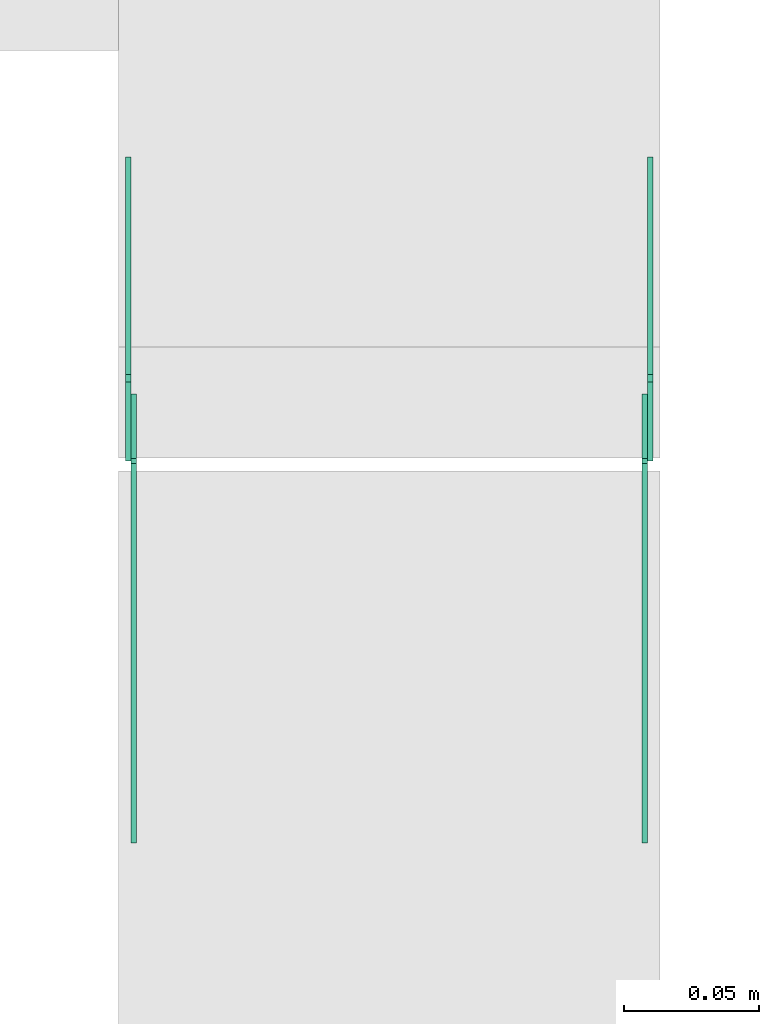
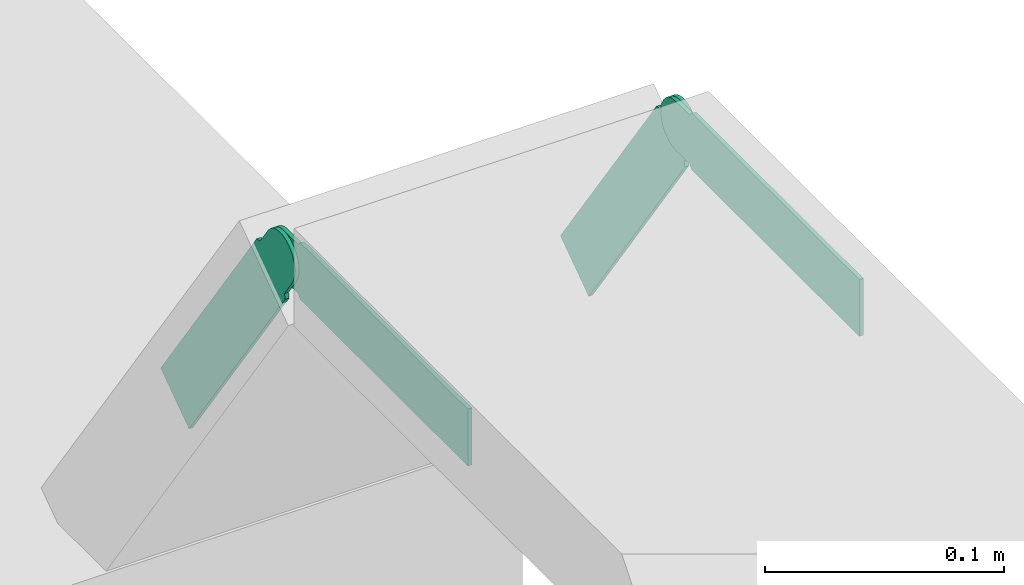
# One storey, part 26 of 27: 4 flow fittings.
"""IFC2X3 building model written with IfcOpenShell, lengths in millimetres."""

from ifc_helpers import new_model, entity, si_unit, converted_unit, derived_unit, direction, frame, frame_2d, origin, place, context, subcontext, project, spatial, polyline, circle_curve, parameter, trimmed, segment, composite_curve, outline, extrude, source, transform, mapped, material, type_object, type_shapes, element, save


model = new_model("IFC2X3")

# Units and contexts
model_context = context("Model", 3, precision=0.01, world=origin(), true_north=direction((6.12303176911189e-17, 1.0)))
body_context = subcontext(model_context, "Body", "Model", "MODEL_VIEW")
ifc_project = project(units=[si_unit("LENGTHUNIT", "METRE", prefix="MILLI"), si_unit("AREAUNIT", "SQUARE_METRE"), si_unit("VOLUMEUNIT", "CUBIC_METRE"), converted_unit("PLANEANGLEUNIT", "DEGREE", entity("IfcRatioMeasure", 0.0174532925199433), si_unit("PLANEANGLEUNIT", "RADIAN"), dimensions=[0, 0, 0, 0, 0, 0, 0]), si_unit("MASSUNIT", "GRAM", prefix="KILO"), derived_unit("MASSDENSITYUNIT", [(si_unit("MASSUNIT", "GRAM", prefix="KILO"), 1), (si_unit("LENGTHUNIT", "METRE"), -3)]), derived_unit("MOMENTOFINERTIAUNIT", [(si_unit("LENGTHUNIT", "METRE"), 4)]), si_unit("TIMEUNIT", "SECOND"), si_unit("FREQUENCYUNIT", "HERTZ"), si_unit("THERMODYNAMICTEMPERATUREUNIT", "DEGREE_CELSIUS"), derived_unit("THERMALTRANSMITTANCEUNIT", [(si_unit("MASSUNIT", "GRAM", prefix="KILO"), 1), (si_unit("THERMODYNAMICTEMPERATUREUNIT", "KELVIN"), -1), (si_unit("TIMEUNIT", "SECOND"), -3)]), derived_unit("VOLUMETRICFLOWRATEUNIT", [(si_unit("LENGTHUNIT", "METRE"), 3), (si_unit("TIMEUNIT", "SECOND"), -1)]), derived_unit("MASSFLOWRATEUNIT", [(si_unit("MASSUNIT", "GRAM", prefix="KILO"), 1), (si_unit("TIMEUNIT", "SECOND"), -1)]), derived_unit("ROTATIONALFREQUENCYUNIT", [(si_unit("TIMEUNIT", "SECOND"), -1)]), si_unit("ELECTRICCURRENTUNIT", "AMPERE"), si_unit("ELECTRICVOLTAGEUNIT", "VOLT"), si_unit("POWERUNIT", "WATT"), si_unit("FORCEUNIT", "NEWTON", prefix="KILO"), si_unit("ILLUMINANCEUNIT", "LUX"), si_unit("LUMINOUSFLUXUNIT", "LUMEN"), si_unit("LUMINOUSINTENSITYUNIT", "CANDELA"), derived_unit("USERDEFINED", [(si_unit("MASSUNIT", "GRAM", prefix="KILO"), -1), (si_unit("LENGTHUNIT", "METRE"), -2), (si_unit("TIMEUNIT", "SECOND"), 3), (si_unit("LUMINOUSFLUXUNIT", "LUMEN"), 1)]), derived_unit("LINEARVELOCITYUNIT", [(si_unit("LENGTHUNIT", "METRE"), 1), (si_unit("TIMEUNIT", "SECOND"), -1)]), si_unit("PRESSUREUNIT", "PASCAL"), derived_unit("USERDEFINED", [(si_unit("LENGTHUNIT", "METRE"), -2), (si_unit("MASSUNIT", "GRAM", prefix="KILO"), 1), (si_unit("TIMEUNIT", "SECOND"), -2)]), derived_unit("LINEARFORCEUNIT", [(si_unit("MASSUNIT", "GRAM", prefix="KILO"), 1), (si_unit("LENGTHUNIT", "METRE"), 1), (si_unit("TIMEUNIT", "SECOND"), -2), (si_unit("LENGTHUNIT", "METRE"), -1)]), derived_unit("PLANARFORCEUNIT", [(si_unit("MASSUNIT", "GRAM", prefix="KILO"), 1), (si_unit("LENGTHUNIT", "METRE"), 1), (si_unit("TIMEUNIT", "SECOND"), -2), (si_unit("LENGTHUNIT", "METRE"), -2)])], contexts=[model_context])

# Site, building, storey
site_placement = place(None, origin())
site = spatial("IfcSite", under=ifc_project, at=site_placement, CompositionType="ELEMENT")
building_placement = place(site_placement, origin())
building = spatial("IfcBuilding", under=site, at=building_placement, CompositionType="ELEMENT")
storey_placement = place(building_placement, origin())
storey = spatial("IfcBuildingStorey", under=building, at=storey_placement, CompositionType="ELEMENT", Elevation=0.0)

# Flow fittings
ifc_material = material(Name="G")
cable_carrier_fitting_type_1 = type_object("IfcCableCarrierFittingType", PredefinedType="NOTDEFINED", material=ifc_material)
shared_shape_1 = source(origin(), body_context, "Body", "SweptSolid", [
    extrude(outline(composite_curve([segment(trimmed(circle_curve(frame_2d((-44.59, 0.0), x_axis=(1.0, 0.0)), 12.5), [parameter(90.0000000000007)], [parameter(270.0)], True, "PARAMETER"), True, "CONTINUOUS"), segment(polyline([(-44.59, -12.5), (-33.09, -12.5)]), True, "CONTINUOUS"), segment(polyline([(-33.09, -12.5), (-31.23, -14.5)]), True, "CONTINUOUS"), segment(polyline([(-31.23, -14.5), (108.91, -14.5)]), True, "CONTINUOUS"), segment(polyline([(108.91, -14.5), (108.91, 14.5)]), True, "CONTINUOUS"), segment(polyline([(108.91, 14.5), (-31.23, 14.5)]), True, "CONTINUOUS"), segment(polyline([(-31.23, 14.5), (-33.09, 12.5)]), True, "CONTINUOUS"), segment(polyline([(-33.09, 12.5), (-44.59, 12.5)]), True, "CONTINUOUS")], self_intersect=False)), frame((44.59, 0.0, 0.0), z_axis=(0.0, 0.0, -1.0), x_axis=(1.0, 0.0, 0.0)), (0.0, 0.0, -1.0), 2.0),
])
type_shapes(cable_carrier_fitting_type_1, [shared_shape_1])
flow_fitting_1_placement = place(storey_placement, frame((63906.72, 19260.61, 2825.0), z_axis=(-1.0, 0.0, 0.0), x_axis=(0.0, 0.57357643635105, -0.819152044288989)))
element("IfcFlowFitting", 1, at=flow_fitting_1_placement, inside=storey, type_object=cable_carrier_fitting_type_1, material=ifc_material, context=body_context, shape_type="MappedRepresentation", body=[
    mapped(shared_shape_1, transform((0.0, 0.0, 0.0), scale=1.0)),
])
cable_carrier_fitting_type_2 = type_object("IfcCableCarrierFittingType", PredefinedType="NOTDEFINED", material=ifc_material)
type_shapes(cable_carrier_fitting_type_2, [shared_shape_1])
flow_fitting_2_placement = place(storey_placement, frame((64095.64, 19260.61, 2825.0), z_axis=(1.0, 0.0, 0.0), x_axis=(0.0, -1.0, 0.0)))
element("IfcFlowFitting", 2, at=flow_fitting_2_placement, inside=storey, type_object=cable_carrier_fitting_type_2, material=ifc_material, context=body_context, shape_type="MappedRepresentation", body=[
    mapped(shared_shape_1, transform((0.0, 0.0, 0.0), scale=1.0)),
])
cable_carrier_fitting_type_3 = type_object("IfcCableCarrierFittingType", PredefinedType="NOTDEFINED", material=ifc_material)
shared_shape_2 = source(origin(), body_context, "Body", "SweptSolid", [
    extrude(outline(composite_curve([segment(trimmed(circle_curve(frame_2d((-44.59, 0.0), x_axis=(1.0, 0.0)), 12.5), [parameter(90.0000000000007)], [parameter(270.0)], True, "PARAMETER"), True, "CONTINUOUS"), segment(polyline([(-44.59, -12.5), (-33.09, -12.5)]), True, "CONTINUOUS"), segment(polyline([(-33.09, -12.5), (-31.23, -14.5)]), True, "CONTINUOUS"), segment(polyline([(-31.23, -14.5), (108.91, -14.5)]), True, "CONTINUOUS"), segment(polyline([(108.91, -14.5), (108.91, 14.5)]), True, "CONTINUOUS"), segment(polyline([(108.91, 14.5), (-31.23, 14.5)]), True, "CONTINUOUS"), segment(polyline([(-31.23, 14.5), (-33.09, 12.5)]), True, "CONTINUOUS"), segment(polyline([(-33.09, 12.5), (-44.59, 12.5)]), True, "CONTINUOUS")], self_intersect=False)), frame((44.59, 0.0, 0.0)), (0.0, 0.0, 1.0), 2.0),
])
type_shapes(cable_carrier_fitting_type_3, [shared_shape_2])
flow_fitting_3_placement = place(storey_placement, frame((64097.64, 19260.61, 2825.0), z_axis=(1.0, 0.0, 0.0), x_axis=(0.0, 0.57357643635105, -0.819152044288989)))
element("IfcFlowFitting", 3, at=flow_fitting_3_placement, inside=storey, type_object=cable_carrier_fitting_type_3, material=ifc_material, context=body_context, shape_type="MappedRepresentation", body=[
    mapped(shared_shape_2, transform((0.0, 0.0, 0.0), scale=1.0)),
])
cable_carrier_fitting_type_4 = type_object("IfcCableCarrierFittingType", PredefinedType="NOTDEFINED", material=ifc_material)
type_shapes(cable_carrier_fitting_type_4, [shared_shape_2])
flow_fitting_4_placement = place(storey_placement, frame((63908.72, 19260.61, 2825.0), z_axis=(-1.0, 0.0, 0.0), x_axis=(0.0, -1.0, 0.0)))
element("IfcFlowFitting", 4, at=flow_fitting_4_placement, inside=storey, type_object=cable_carrier_fitting_type_4, material=ifc_material, context=body_context, shape_type="MappedRepresentation", body=[
    mapped(shared_shape_2, transform((0.0, 0.0, 0.0), scale=1.0)),
])

save(model, "model.ifc")
